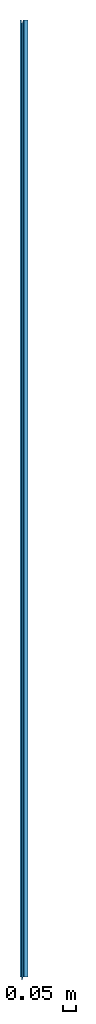
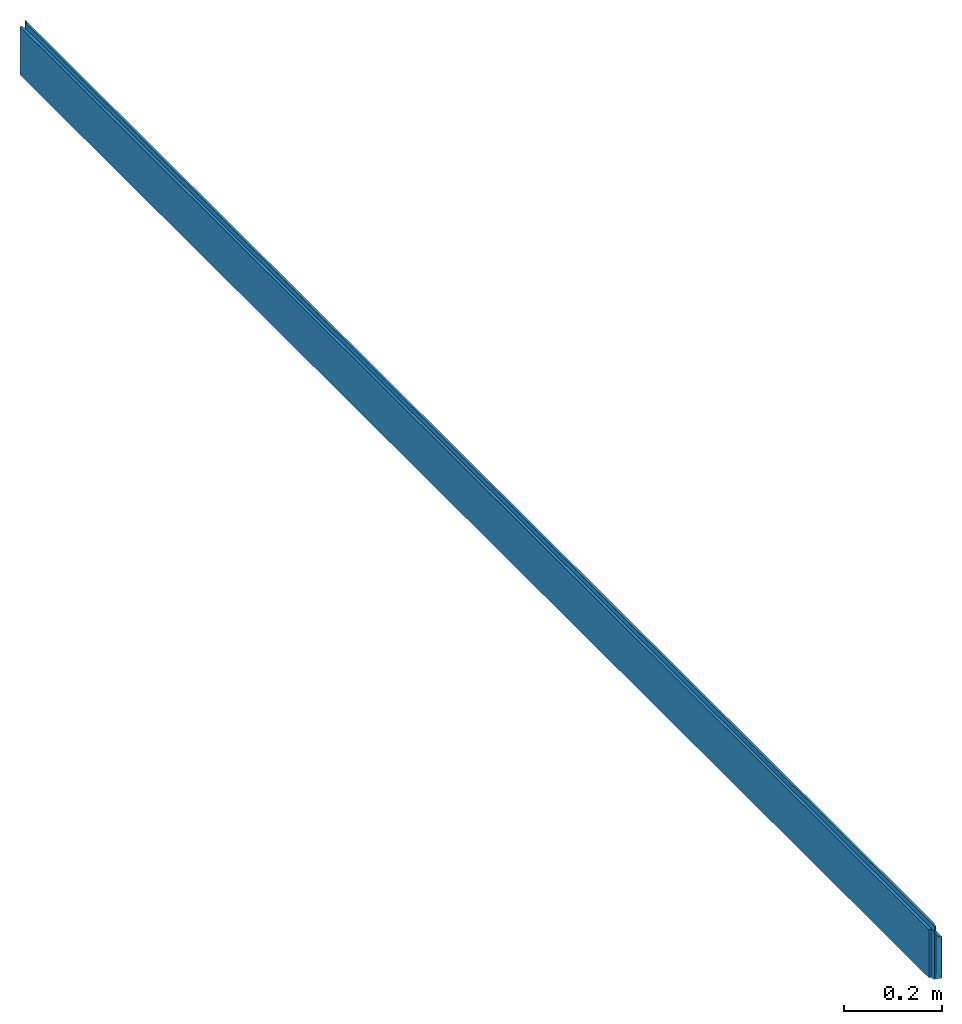
# One storey: 1 beam.
"""IFC2X3 building model written with IfcOpenShell, lengths in metres."""

from ifc_helpers import new_model, si_unit, frame, origin_with_axes, place, context, project, spatial, faceted_brep, material, element, save


model = new_model("IFC2X3")

# Units and contexts
model_context = context("Model", 3, precision=1e-06, world=origin_with_axes())
ifc_project = project(units=[si_unit("LENGTHUNIT", "METRE"), si_unit("PLANEANGLEUNIT", "RADIAN")], contexts=[model_context])

# Site, building, storey
site_placement = place(None, origin_with_axes())
site = spatial("IfcSite", under=ifc_project, at=site_placement, CompositionType="ELEMENT")
building_placement = place(None, origin_with_axes())
building = spatial("IfcBuilding", under=site, at=building_placement, Name="Building 1", CompositionType="ELEMENT")
storey_placement = place(None, origin_with_axes())
storey = spatial("IfcBuildingStorey", under=building, at=storey_placement, CompositionType="ELEMENT", Elevation=0.0)

# Beam
ifc_material = material()
beam_placement = place(None, frame((0.015500000000001, -0.011500000000008, 0.060574216573399), z_axis=(0.0, 0.0, -1.0), x_axis=(0.0, 1.0, 0.0)))
element("IfcBeam", 1, at=beam_placement, inside=storey, material=ifc_material, context=model_context, shape_type="Brep", body=[
    faceted_brep([(3.710000000000033, 0.015500000000001, -0.030525783428047), (3.710000000000033, 0.015500000000001, 0.071425783426703), (3.711500000000033, 0.014000000000001, 0.071153688379974), (3.711500000000033, 0.014000000000001, -0.031414814966814), (3.711500000000033, 0.014000000000001, -0.031414814966814), (3.711500000000033, 0.014000000000001, 0.071153688379974), (3.711500000000033, -0.000810714285757, 0.068467073716196), (3.711500000000033, -0.00279999999992, 0.04857421657337), (3.711500000000033, -0.004301496268633, 0.048574216573357), (3.711500000000033, -0.004301496268633, -0.071425783426672), (3.711500000000033, -0.00279999999992, -0.071425783426659), (3.711500000000033, -0.000810714285757, -0.051532926283824), (3.711500000000033, -0.000810714285757, -0.040192943041284), (3.711500000000033, 0.014000000000001, 0.071153688379974), (3.710000000000033, 0.015500000000001, 0.071425783426703), (0.01300000000001, 0.015500000000001, 0.071425783426703), (0.011500000000009, 0.014, 0.071153688379974), (0.011500000000009, -0.000810714285757, 0.068467073716196), (3.711500000000033, -0.000810714285757, 0.068467073716196), (0.01300000000001, 0.015500000000001, 0.071425783426703), (0.01300000000001, 0.015500000000001, -0.030525783428047), (0.011500000000009, 0.014, -0.031414814966814), (0.011500000000009, 0.014, 0.071153688379974), (0.011500000000009, 0.014, 0.071153688379974), (0.011500000000009, 0.014, -0.031414814966814), (0.011500000000009, -0.000810714285757, -0.040192943041284), (0.011500000000009, -0.000810714285757, -0.051532926283824), (0.011500000000009, -0.00279999999992, -0.071425783426659), (0.011500000000009, -0.004301496268629, -0.071425783426672), (0.011500000000009, -0.004301496268629, 0.048574216573357), (0.011500000000009, -0.00279999999992, 0.04857421657337), (0.011500000000009, -0.000810714285757, 0.068467073716196), (3.710000000000033, 0.015500000000001, -0.030525783428047), (3.711500000000033, 0.014000000000001, -0.031414814966814), (3.711500000000033, -0.000810714285757, -0.040192943041284), (0.011500000000009, -0.000810714285757, -0.040192943041284), (0.011500000000009, 0.014, -0.031414814966814), (0.01300000000001, 0.015500000000001, -0.030525783428047), (3.7, -0.005451496268548, 0.048574216573348), (3.7, -0.005451496268548, -0.071425783426681), (3.711500000000033, -0.004301496268633, -0.071425783426672), (3.711500000000033, -0.004301496268633, 0.048574216573357), (3.7, -0.008000000000006, 0.048574216573326), (3.7, -0.009199999999987, 0.060574216573414), (3.7, -0.009548503728396, 0.060574216573413), (3.7, -0.009548503728396, -0.05942578342663), (3.7, -0.009199999999987, -0.05942578342663), (3.7, -0.008000000000006, -0.071425783426703), (3.7, -0.005451496268548, -0.071425783426681), (3.7, -0.005451496268548, 0.048574216573348), (3.711500000000033, -0.010698503728366, 0.06057421657341), (3.711500000000033, -0.010698503728366, -0.05942578342663), (3.7, -0.009548503728396, -0.05942578342663), (3.7, -0.009548503728396, 0.060574216573413), (3.7, -0.008000000000006, 0.048574216573326), (3.7, -0.005451496268548, 0.048574216573348), (3.711500000000033, -0.004301496268633, 0.048574216573357), (3.711500000000033, -0.00279999999992, 0.04857421657337), (0.011500000000009, -0.00279999999992, 0.04857421657337), (0.011500000000009, -0.004301496268629, 0.048574216573357), (0.0, -0.005451496268547, 0.048574216573348), (0.0, -0.008000000000006, 0.048574216573326), (3.711500000000033, -0.004301496268633, -0.071425783426672), (3.7, -0.005451496268548, -0.071425783426681), (3.7, -0.008000000000006, -0.071425783426703), (0.0, -0.008000000000006, -0.071425783426703), (0.0, -0.005451496268547, -0.071425783426681), (0.011500000000009, -0.004301496268629, -0.071425783426672), (0.011500000000009, -0.00279999999992, -0.071425783426659), (3.711500000000033, -0.00279999999992, -0.071425783426659), (3.711500000000033, -0.010698503728366, -0.05942578342663), (3.711500000000033, -0.010698503728366, 0.06057421657341), (3.711500000000033, -0.015500000000001, 0.060574216573399), (3.711500000000033, -0.015500000000001, -0.05942578342663), (3.7, -0.008000000000006, -0.071425783426703), (3.7, -0.009199999999987, -0.05942578342663), (0.0, -0.009199999999987, -0.05942578342663), (0.0, -0.008000000000006, -0.071425783426703), (0.011500000000033, -0.010698503728365, 0.06057421657341), (0.011500000000033, -0.010698503728365, -0.05942578342663), (0.011500000000009, -0.015500000000001, -0.05942578342663), (0.011500000000008, -0.015500000000001, 0.060574216573399), (0.0, -0.009548503728395, 0.060574216573413), (0.0, -0.009548503728395, -0.05942578342663), (0.011500000000033, -0.010698503728365, -0.05942578342663), (0.011500000000033, -0.010698503728365, 0.06057421657341), (0.011500000000008, -0.015500000000001, 0.060574216573399), (0.011500000000009, -0.015500000000001, -0.05942578342663), (3.711500000000033, -0.015500000000001, -0.05942578342663), (3.711500000000033, -0.015500000000001, 0.060574216573399), (3.7, -0.009548503728396, -0.05942578342663), (3.711500000000033, -0.010698503728366, -0.05942578342663), (3.711500000000033, -0.015500000000001, -0.05942578342663), (0.011500000000009, -0.015500000000001, -0.05942578342663), (0.011500000000033, -0.010698503728365, -0.05942578342663), (0.0, -0.009548503728395, -0.05942578342663), (0.0, -0.009199999999987, -0.05942578342663), (3.7, -0.009199999999987, -0.05942578342663), (0.0, -0.005451496268547, -0.071425783426681), (0.0, -0.005451496268547, 0.048574216573348), (0.011500000000009, -0.004301496268629, 0.048574216573357), (0.011500000000009, -0.004301496268629, -0.071425783426672), (3.710000000000033, 0.015500000000001, 0.071425783426703), (3.710000000000033, 0.015500000000001, -0.030525783428047), (0.01300000000001, 0.015500000000001, -0.030525783428047), (0.01300000000001, 0.015500000000001, 0.071425783426703), (0.011500000000009, -0.000810714285757, 0.068467073716196), (0.011500000000009, -0.00279999999992, 0.04857421657337), (3.711500000000033, -0.00279999999992, 0.04857421657337), (3.711500000000033, -0.000810714285757, 0.068467073716196), (0.0, -0.009548503728395, -0.05942578342663), (0.0, -0.009548503728395, 0.060574216573413), (0.0, -0.009199999999987, 0.060574216573414), (0.0, -0.008000000000006, 0.048574216573326), (0.0, -0.005451496268547, 0.048574216573348), (0.0, -0.005451496268547, -0.071425783426681), (0.0, -0.008000000000006, -0.071425783426703), (0.0, -0.009199999999987, -0.05942578342663), (3.7, -0.009199999999987, 0.060574216573414), (3.7, -0.008000000000006, 0.048574216573326), (0.0, -0.008000000000006, 0.048574216573326), (0.0, -0.009199999999987, 0.060574216573414), (0.011500000000009, -0.000810714285757, -0.051532926283824), (0.011500000000009, -0.000810714285757, -0.040192943041284), (3.711500000000033, -0.000810714285757, -0.040192943041284), (3.711500000000033, -0.000810714285757, -0.051532926283824), (0.011500000000009, -0.00279999999992, -0.071425783426659), (0.011500000000009, -0.000810714285757, -0.051532926283824), (3.711500000000033, -0.000810714285757, -0.051532926283824), (3.711500000000033, -0.00279999999992, -0.071425783426659), (3.7, -0.009548503728396, 0.060574216573413), (3.7, -0.009199999999987, 0.060574216573414), (0.0, -0.009199999999987, 0.060574216573414), (0.0, -0.009548503728395, 0.060574216573413), (0.011500000000033, -0.010698503728365, 0.06057421657341), (0.011500000000008, -0.015500000000001, 0.060574216573399), (3.711500000000033, -0.015500000000001, 0.060574216573399), (3.711500000000033, -0.010698503728366, 0.06057421657341)], [[[0, 1, 2, 3]], [[4, 5, 6, 7, 8, 9, 10, 11, 12]], [[13, 14, 15, 16, 17, 18]], [[19, 20, 21, 22]], [[23, 24, 25, 26, 27, 28, 29, 30, 31]], [[32, 33, 34, 35, 36, 37]], [[38, 39, 40, 41]], [[42, 43, 44, 45, 46, 47, 48, 49]], [[50, 51, 52, 53]], [[54, 55, 56, 57, 58, 59, 60, 61]], [[62, 63, 64, 65, 66, 67, 68, 69]], [[70, 71, 72, 73]], [[74, 75, 76, 77]], [[78, 79, 80, 81]], [[82, 83, 84, 85]], [[86, 87, 88, 89]], [[90, 91, 92, 93, 94, 95, 96, 97]], [[98, 99, 100, 101]], [[102, 103, 104, 105]], [[106, 107, 108, 109]], [[110, 111, 112, 113, 114, 115, 116, 117]], [[118, 119, 120, 121]], [[122, 123, 124, 125]], [[126, 127, 128, 129]], [[130, 131, 132, 133, 134, 135, 136, 137]]]),
])

save(model, "model.ifc")
